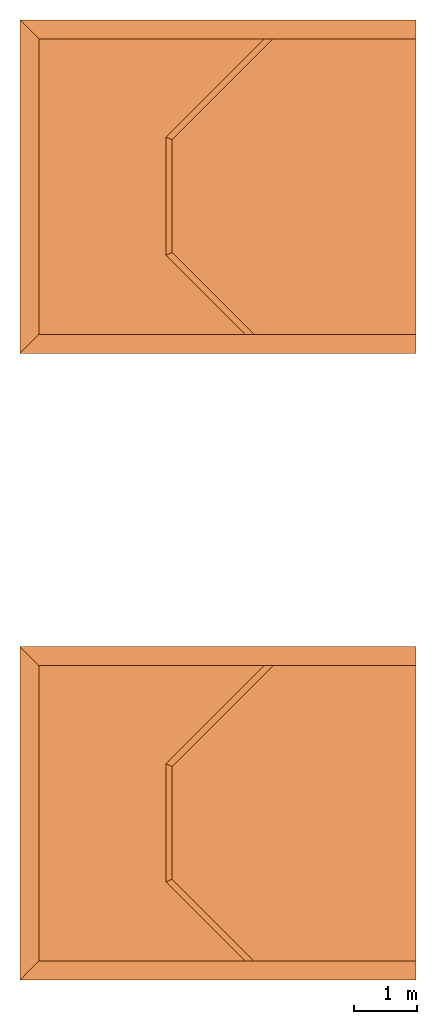
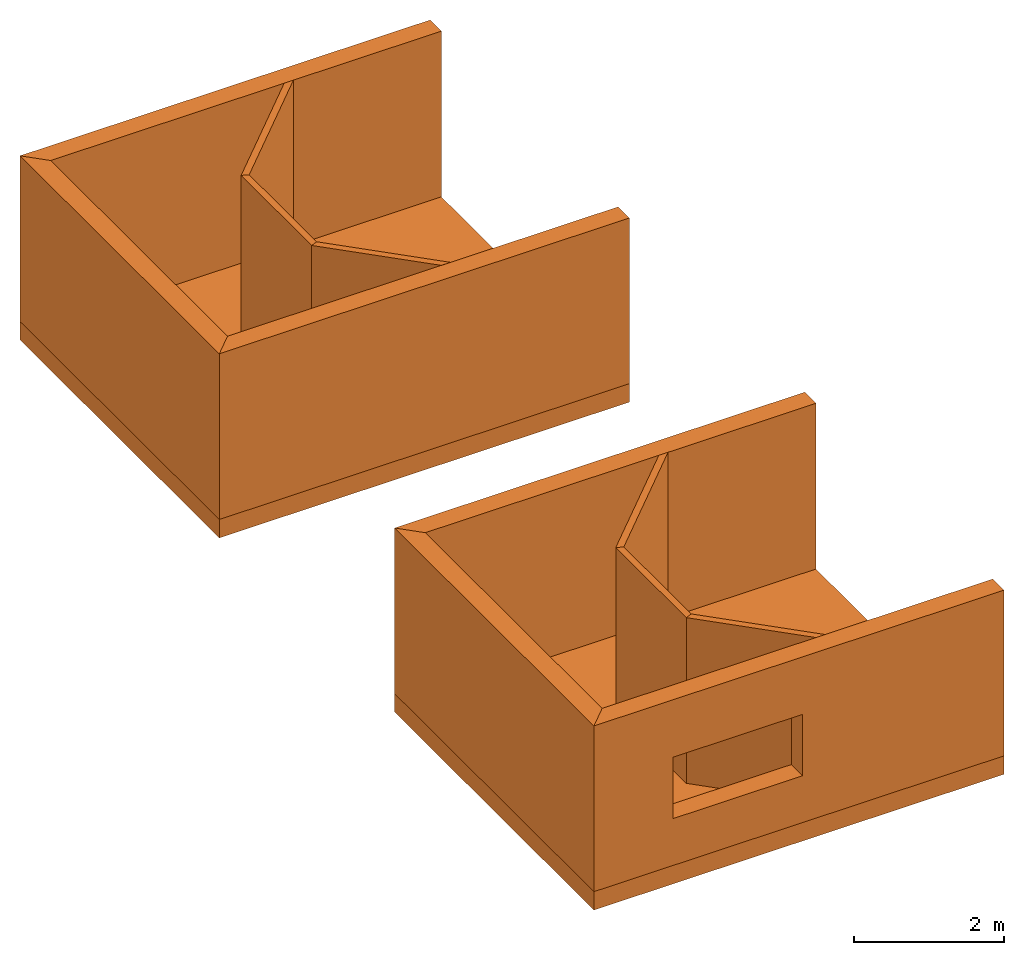
# One storey: 14 proxies, 1 opening.
"""IFC2X3 building model written with IfcOpenShell, lengths in metres."""

from ifc_helpers import new_model, entity, si_unit, converted_unit, derived_unit, money_unit, direction, frame, origin_with_axes, origin_2d_with_axis, place, context, subcontext, project, spatial, polyline, rectangle, outline, extrude, material, type_object, element, save


model = new_model("IFC2X3")

# Units and contexts
model_context = context("Model", 3, precision=1e-05, world=origin_with_axes(), true_north=direction((0.0, 1.0)))
body_context = subcontext(model_context, "Body", "Model", "MODEL_VIEW")
ifc_project = project(units=[si_unit("LENGTHUNIT", "METRE"), si_unit("AREAUNIT", "SQUARE_METRE"), si_unit("VOLUMEUNIT", "CUBIC_METRE"), converted_unit("PLANEANGLEUNIT", "DEGREE", entity("IfcPlaneAngleMeasure", 0.0174532925199433), si_unit("PLANEANGLEUNIT", "RADIAN"), dimensions=[0, 0, 0, 0, 0, 0, 0]), money_unit("EUR"), converted_unit("TIMEUNIT", "Year", entity("IfcTimeMeasure", 31557600.0), si_unit("TIMEUNIT", "SECOND"), dimensions=[0, 0, 1, 0, 0, 0, 0]), si_unit("MASSUNIT", "GRAM", prefix="KILO"), si_unit("THERMODYNAMICTEMPERATUREUNIT", "DEGREE_CELSIUS"), si_unit("LUMINOUSINTENSITYUNIT", "LUMEN"), si_unit("ENERGYUNIT", "JOULE", prefix="MEGA"), derived_unit("THERMALCONDUCTANCEUNIT", [(si_unit("POWERUNIT", "WATT"), 1), (si_unit("LENGTHUNIT", "METRE"), -1), (si_unit("THERMODYNAMICTEMPERATUREUNIT", "KELVIN"), -1)]), derived_unit("SPECIFICHEATCAPACITYUNIT", [(si_unit("ENERGYUNIT", "JOULE"), 1), (si_unit("MASSUNIT", "GRAM", prefix="KILO"), -1), (si_unit("THERMODYNAMICTEMPERATUREUNIT", "KELVIN"), -1)]), derived_unit("MASSDENSITYUNIT", [(si_unit("MASSUNIT", "GRAM", prefix="KILO"), 1), (si_unit("VOLUMEUNIT", "CUBIC_METRE"), -1)])], contexts=[model_context])

# Site, building, storey
site_placement = place(None, origin_with_axes())
site = spatial("IfcSite", under=ifc_project, at=site_placement, CompositionType="ELEMENT")
building_placement = place(site_placement, origin_with_axes())
building = spatial("IfcBuilding", under=site, at=building_placement, Name="Edificio", CompositionType="ELEMENT")
storey_placement = place(building_placement, origin_with_axes())
storey = spatial("IfcBuildingStorey", under=building, at=storey_placement, Name="L00", CompositionType="ELEMENT", Elevation=0.0)

# Proxy, opening
ifc_material_1 = material(Name="Cemento Strutturale")
building_element_proxy_type_1 = type_object("IfcBuildingElementProxyType", Name="Cemento Strutturale 300", PredefinedType="NOTDEFINED")
proxy_1_placement = place(storey_placement, frame((-0.16, -0.16, 0.0), z_axis=(0.0, 0.0, 1.0), x_axis=(1.0, 0.0, 0.0)))
proxy_1 = element("IfcBuildingElementProxy", 1, at=proxy_1_placement, inside=storey, type_object=building_element_proxy_type_1, material=ifc_material_1, Name="MUR_001", context=body_context, shape_type="SweptSolid", body=[
    extrude(outline(polyline([(0.0, 0.0), (6.32, 0.0), (6.32, 0.2999999999999999), (0.2999999999999997, 0.2999999999999999), (0.0, 0.0)])), origin_with_axes(), (0.0, 0.0, 1.0), 2.7),
])
opening_placement = place(proxy_1_placement, frame((0.16, 0.16, 0.0), z_axis=(0.0, 0.0, 1.0), x_axis=(1.0, 0.0, 0.0)))
element("IfcOpeningElement", 2, at=opening_placement, cuts=proxy_1, Name="AP - 002", ObjectType="Empty Opening", context=body_context, shape_type="SweptSolid", body=[
    extrude(rectangle(XDim=2.0, YDim=1.0, at=origin_2d_with_axis()), frame((2.055270866724479, -0.46, 1.263392024415401), z_axis=(0.0, -1.0, 0.0), x_axis=(1.0, 0.0, 0.0)), (0.0, 0.0, -1.0), 0.8999999999999999),
])

# Proxies
proxy_2_placement = place(storey_placement, frame((-0.16, 5.16, 0.0), z_axis=(0.0, 0.0, 1.0), x_axis=(0.0, -1.0, 0.0)))
element("IfcBuildingElementProxy", 3, at=proxy_2_placement, inside=storey, type_object=building_element_proxy_type_1, material=ifc_material_1, Name="MUR_003", context=body_context, shape_type="SweptSolid", body=[
    extrude(outline(polyline([(0.0, 0.0), (5.32, 0.0), (5.02, 0.3), (0.2999999999999998, 0.3), (0.0, 0.0)])), origin_with_axes(), (0.0, 0.0, 1.0), 2.7),
])
proxy_3_placement = place(storey_placement, frame((6.16, 5.16, 0.0), z_axis=(0.0, 0.0, 1.0), x_axis=(-1.0, 0.0, 0.0)))
element("IfcBuildingElementProxy", 4, at=proxy_3_placement, inside=storey, type_object=building_element_proxy_type_1, material=ifc_material_1, Name="MUR_002", context=body_context, shape_type="SweptSolid", body=[
    extrude(outline(polyline([(0.0, 0.0), (6.32, 0.0), (6.02, 0.2999999999999998), (0.0, 0.2999999999999998), (0.0, 0.0)])), origin_with_axes(), (0.0, 0.0, 1.0), 2.7),
])
proxy_4_placement = place(storey_placement, frame((-0.1599999999999991, 9.84, 0.0), z_axis=(0.0, 0.0, 1.0), x_axis=(1.0, 0.0, 0.0)))
element("IfcBuildingElementProxy", 5, at=proxy_4_placement, inside=storey, type_object=building_element_proxy_type_1, material=ifc_material_1, Name="MUR_012", context=body_context, shape_type="SweptSolid", body=[
    extrude(outline(polyline([(0.0, 0.0), (6.32, 0.0), (6.32, 0.3000000000000007), (0.2999999999999997, 0.3000000000000007), (0.0, 0.0)])), origin_with_axes(), (0.0, 0.0, 1.0), 2.7),
])
proxy_5_placement = place(storey_placement, frame((6.160000000000001, 15.16, 0.0), z_axis=(0.0, 0.0, 1.0), x_axis=(-1.0, 0.0, 0.0)))
element("IfcBuildingElementProxy", 6, at=proxy_5_placement, inside=storey, type_object=building_element_proxy_type_1, material=ifc_material_1, Name="MUR_013", context=body_context, shape_type="SweptSolid", body=[
    extrude(outline(polyline([(0.0, 0.0), (6.32, 0.0), (6.02, 0.3000000000000007), (0.0, 0.3000000000000007), (0.0, 0.0)])), origin_with_axes(), (0.0, 0.0, 1.0), 2.7),
])
proxy_6_placement = place(storey_placement, frame((-0.1599999999999991, 15.16, 0.0), z_axis=(0.0, 0.0, 1.0), x_axis=(0.0, -1.0, 0.0)))
element("IfcBuildingElementProxy", 7, at=proxy_6_placement, inside=storey, type_object=building_element_proxy_type_1, material=ifc_material_1, Name="MUR_014", context=body_context, shape_type="SweptSolid", body=[
    extrude(outline(polyline([(0.0, 0.0), (5.32, 0.0), (5.02, 0.3), (0.3000000000000007, 0.3), (0.0, 0.0)])), origin_with_axes(), (0.0, 0.0, 1.0), 2.7),
])
ifc_material_2 = material(Name="Cemento - Strutturale")
building_element_proxy_type_2 = type_object("IfcBuildingElementProxyType", Name="Cemento - Strutturale 300", PredefinedType="NOTDEFINED")
for number, where, z_axis, x_axis, name in (
    (8, (-0.16, -0.16, 0.0), (0.0, 0.0, 1.0), (1.0, 0.0, 0.0), "SOL_004"),
    (9, (-0.1599999999999991, 9.84, 0.0), (0.0, 0.0, 1.0), (1.0, 0.0, 0.0), "SOL_008"),
):
    element("IfcBuildingElementProxy", number, at=place(storey_placement, frame(where, z_axis=z_axis, x_axis=x_axis)), inside=storey, type_object=building_element_proxy_type_2, material=ifc_material_2, Name=name, context=body_context, shape_type="SweptSolid", body=[
        extrude(outline(polyline([(0.0, 0.0), (6.32, 0.0), (6.32, 5.32), (0.0, 5.32), (0.0, 0.0)])), frame((0.0, 0.0, -0.3), z_axis=(0.0, 0.0, 1.0), x_axis=(1.0, 0.0, 0.0)), (0.0, 0.0, 1.0), 0.3),
    ])
ifc_material_3 = material(Name="Mattone")
building_element_proxy_type_3 = type_object("IfcBuildingElementProxyType", Name="Mattone 100", PredefinedType="NOTDEFINED")
proxy_7_placement = place(storey_placement, frame((4.038700531402434, 5.16, 0.0), z_axis=(0.0, 0.0, 1.0), x_axis=(-0.7071067811865478, -0.7071067811865475, 0.0)))
element("IfcBuildingElementProxy", 10, at=proxy_7_placement, inside=storey, type_object=building_element_proxy_type_3, material=ifc_material_3, Name="MUR_007", context=body_context, shape_type="SweptSolid", body=[
    extrude(outline(polyline([(0.4242640687119277, 0.0), (2.645145489964096, 0.0), (2.603724133726787, 0.1000000000000001), (0.324264068711928, 0.09999999999999964), (0.4242640687119277, 0.0)])), origin_with_axes(), (0.0, 0.0, 1.0), 2.7),
])
proxy_8_placement = place(storey_placement, frame((2.168300218223807, 3.289599686821375, 0.0), z_axis=(0.0, 0.0, 1.0), x_axis=(0.0, -1.0, 0.0)))
element("IfcBuildingElementProxy", 11, at=proxy_8_placement, inside=storey, type_object=building_element_proxy_type_3, material=ifc_material_3, Name="MUR_008", context=body_context, shape_type="SweptSolid", body=[
    extrude(outline(polyline([(0.0, 0.0), (1.882668124632313, 0.0), (1.841246768395003, 0.1000000000000001), (0.04142135623730958, 0.1000000000000001), (0.0, 0.0)])), origin_with_axes(), (0.0, 0.0, 1.0), 2.7),
])
proxy_9_placement = place(storey_placement, frame((2.168300218223807, 1.406931562189062, 0.0), z_axis=(0.0, 0.0, 1.0), x_axis=(0.7071067811865472, -0.7071067811865478, 0.0)))
element("IfcBuildingElementProxy", 12, at=proxy_9_placement, inside=storey, type_object=building_element_proxy_type_3, material=ifc_material_3, Name="MUR_009", context=body_context, shape_type="SweptSolid", body=[
    extrude(outline(polyline([(0.0, 0.0), (1.791711797846304, 0.0), (1.891711797846303, 0.09999999999999964), (0.04142135623730936, 0.09999999999999964), (0.0, 0.0)])), origin_with_axes(), (0.0, 0.0, 1.0), 2.7),
])
proxy_10_placement = place(storey_placement, frame((4.038700531402434, 15.16, 0.0), z_axis=(0.0, 0.0, 1.0), x_axis=(-0.7071067811865479, -0.7071067811865472, 0.0)))
element("IfcBuildingElementProxy", 13, at=proxy_10_placement, inside=storey, type_object=building_element_proxy_type_3, material=ifc_material_3, Name="MUR_018", context=body_context, shape_type="SweptSolid", body=[
    extrude(outline(polyline([(0.4242640687119277, 0.0), (2.645145489964095, 0.0), (2.603724133726786, 0.09999999999999964), (0.324264068711928, 0.1000000000000005), (0.4242640687119277, 0.0)])), origin_with_axes(), (0.0, 0.0, 1.0), 2.7),
])
proxy_11_placement = place(storey_placement, frame((2.168300218223808, 13.28959968682138, 0.0), z_axis=(0.0, 0.0, 1.0), x_axis=(0.0, -1.0, 0.0)))
element("IfcBuildingElementProxy", 14, at=proxy_11_placement, inside=storey, type_object=building_element_proxy_type_3, material=ifc_material_3, Name="MUR_019", context=body_context, shape_type="SweptSolid", body=[
    extrude(outline(polyline([(0.0, 0.0), (1.882668124632314, 0.0), (1.841246768395004, 0.1000000000000001), (0.04142135623730958, 0.1000000000000001), (0.0, 0.0)])), origin_with_axes(), (0.0, 0.0, 1.0), 2.7),
])
proxy_12_placement = place(storey_placement, frame((2.168300218223808, 11.40693156218906, 0.0), z_axis=(0.0, 0.0, 1.0), x_axis=(0.7071067811865474, -0.7071067811865478, 0.0)))
element("IfcBuildingElementProxy", 15, at=proxy_12_placement, inside=storey, type_object=building_element_proxy_type_3, material=ifc_material_3, Name="MUR_020", context=body_context, shape_type="SweptSolid", body=[
    extrude(outline(polyline([(0.0, 0.0), (1.791711797846302, 0.0), (1.891711797846302, 0.09999999999999964), (0.04142135623730958, 0.1000000000000014), (0.0, 0.0)])), origin_with_axes(), (0.0, 0.0, 1.0), 2.7),
])

save(model, "model.ifc")
